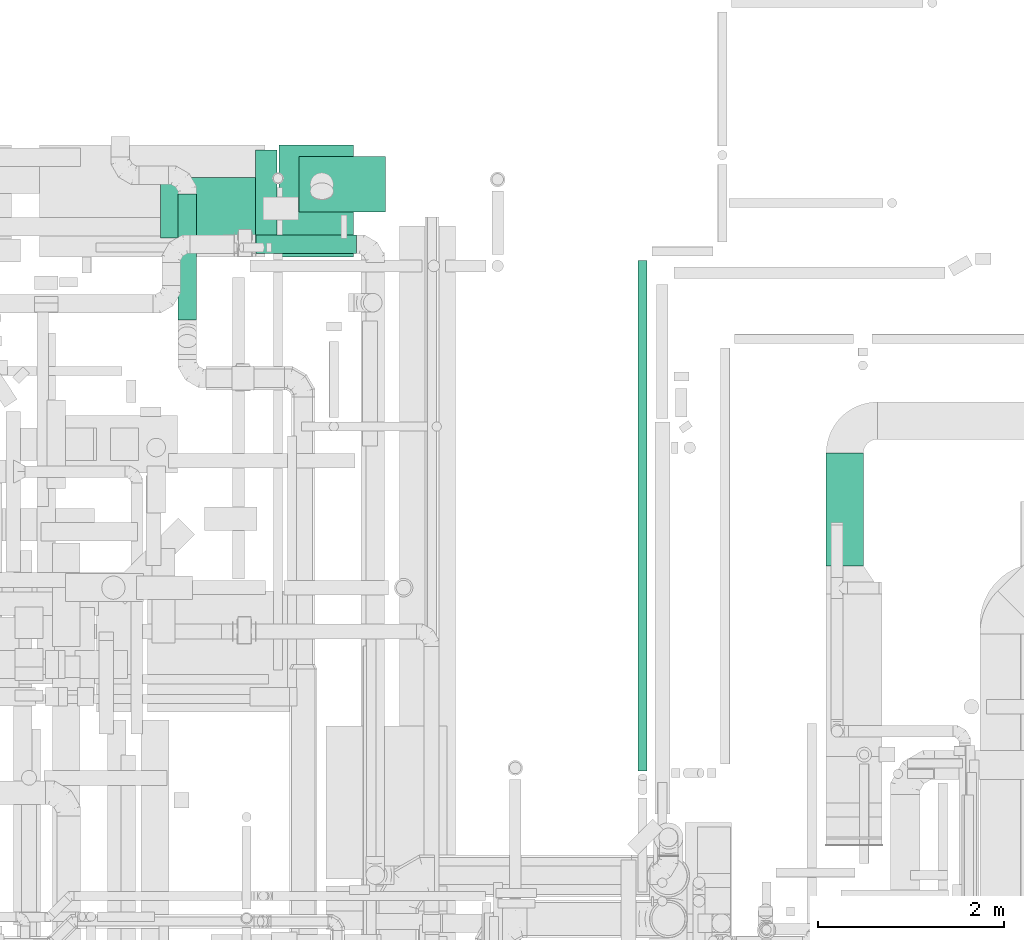
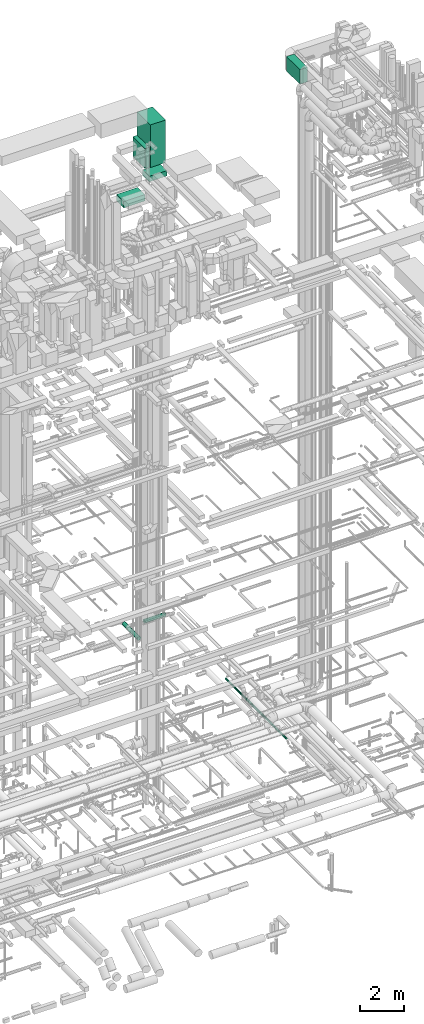
# One storey, part 79 of 337: 8 flow segments.
"""IFC2X3 building model written with IfcOpenShell, lengths in millimetres."""

from ifc_helpers import new_model, entity, si_unit, converted_unit, derived_unit, direction, frame, origin, origin_2d_with_axis, place, context, subcontext, project, spatial, rectangle, circle, extrude, type_object, element, save


model = new_model("IFC2X3")

# Units and contexts
model_context = context("Model", 3, precision=0.01, world=origin(), true_north=direction((6.12303176911189e-17, 1.0)))
body_context = subcontext(model_context, "Body", "Model", "MODEL_VIEW")
ifc_project = project(units=[si_unit("LENGTHUNIT", "METRE", prefix="MILLI"), si_unit("AREAUNIT", "SQUARE_METRE"), si_unit("VOLUMEUNIT", "CUBIC_METRE"), converted_unit("PLANEANGLEUNIT", "DEGREE", entity("IfcRatioMeasure", 0.0174532925199433), si_unit("PLANEANGLEUNIT", "RADIAN"), dimensions=[0, 0, 0, 0, 0, 0, 0]), si_unit("MASSUNIT", "GRAM", prefix="KILO"), derived_unit("MASSDENSITYUNIT", [(si_unit("MASSUNIT", "GRAM", prefix="KILO"), 1), (si_unit("LENGTHUNIT", "METRE"), -3)]), derived_unit("MOMENTOFINERTIAUNIT", [(si_unit("LENGTHUNIT", "METRE"), 4)]), si_unit("TIMEUNIT", "SECOND"), si_unit("FREQUENCYUNIT", "HERTZ"), si_unit("THERMODYNAMICTEMPERATUREUNIT", "DEGREE_CELSIUS"), derived_unit("THERMALTRANSMITTANCEUNIT", [(si_unit("MASSUNIT", "GRAM", prefix="KILO"), 1), (si_unit("THERMODYNAMICTEMPERATUREUNIT", "KELVIN"), -1), (si_unit("TIMEUNIT", "SECOND"), -3)]), derived_unit("VOLUMETRICFLOWRATEUNIT", [(si_unit("LENGTHUNIT", "METRE"), 3), (si_unit("TIMEUNIT", "SECOND"), -1)]), derived_unit("MASSFLOWRATEUNIT", [(si_unit("MASSUNIT", "GRAM", prefix="KILO"), 1), (si_unit("TIMEUNIT", "SECOND"), -1)]), derived_unit("ROTATIONALFREQUENCYUNIT", [(si_unit("TIMEUNIT", "SECOND"), -1)]), si_unit("ELECTRICCURRENTUNIT", "AMPERE"), si_unit("ELECTRICVOLTAGEUNIT", "VOLT"), si_unit("POWERUNIT", "WATT"), si_unit("FORCEUNIT", "NEWTON", prefix="KILO"), si_unit("ILLUMINANCEUNIT", "LUX"), si_unit("LUMINOUSFLUXUNIT", "LUMEN"), si_unit("LUMINOUSINTENSITYUNIT", "CANDELA"), derived_unit("USERDEFINED", [(si_unit("MASSUNIT", "GRAM", prefix="KILO"), -1), (si_unit("LENGTHUNIT", "METRE"), -2), (si_unit("TIMEUNIT", "SECOND"), 3), (si_unit("LUMINOUSFLUXUNIT", "LUMEN"), 1)]), derived_unit("LINEARVELOCITYUNIT", [(si_unit("LENGTHUNIT", "METRE"), 1), (si_unit("TIMEUNIT", "SECOND"), -1)]), si_unit("PRESSUREUNIT", "PASCAL"), derived_unit("USERDEFINED", [(si_unit("LENGTHUNIT", "METRE"), -2), (si_unit("MASSUNIT", "GRAM", prefix="KILO"), 1), (si_unit("TIMEUNIT", "SECOND"), -2)]), derived_unit("LINEARFORCEUNIT", [(si_unit("MASSUNIT", "GRAM", prefix="KILO"), 1), (si_unit("LENGTHUNIT", "METRE"), 1), (si_unit("TIMEUNIT", "SECOND"), -2), (si_unit("LENGTHUNIT", "METRE"), -1)]), derived_unit("PLANARFORCEUNIT", [(si_unit("MASSUNIT", "GRAM", prefix="KILO"), 1), (si_unit("LENGTHUNIT", "METRE"), 1), (si_unit("TIMEUNIT", "SECOND"), -2), (si_unit("LENGTHUNIT", "METRE"), -2)])], contexts=[model_context])

# Site, building, storey
site_placement = place(None, origin())
site = spatial("IfcSite", under=ifc_project, at=site_placement, CompositionType="ELEMENT")
building_placement = place(site_placement, origin())
building = spatial("IfcBuilding", under=site, at=building_placement, CompositionType="ELEMENT")
storey_placement = place(building_placement, origin())
storey = spatial("IfcBuildingStorey", under=building, at=storey_placement, CompositionType="ELEMENT", Elevation=0.0)

# Flow segments
duct_segment_type_1 = type_object("IfcDuctSegmentType", PredefinedType="NOTDEFINED")
flow_segment_1_placement = place(storey_placement, frame((63590.82, 19383.98, 27450.0)))
element("IfcFlowSegment", 1, at=flow_segment_1_placement, inside=storey, type_object=duct_segment_type_1, context=body_context, shape_type="SweptSolid", body=[
    extrude(rectangle(XDim=929.178951127788, YDim=599.999999999998, at=origin_2d_with_axis()), frame((464.59, 300.0, 0.0), z_axis=(0.0, 0.0, 1.0), x_axis=(-1.0, 0.0, 0.0)), (0.0, 0.0, 1.0), 300.000000000001),
])
flow_segment_2_placement = place(storey_placement, frame((63373.17, 18904.6, 28600.0)))
element("IfcFlowSegment", 2, at=flow_segment_2_placement, inside=storey, type_object=duct_segment_type_1, context=body_context, shape_type="SweptSolid", body=[
    extrude(rectangle(XDim=799.999999999991, YDim=1200.0, at=origin_2d_with_axis()), frame((400.0, 600.0, 0.0), z_axis=(0.0, 0.0, 1.0), x_axis=(-1.0, 0.0, 0.0)), (0.0, 0.0, 1.0), 2349.99997500001),
])
flow_segment_3_placement = place(storey_placement, frame((69255.37, 15583.61, 33150.0)))
element("IfcFlowSegment", 3, at=flow_segment_3_placement, inside=storey, type_object=duct_segment_type_1, context=body_context, shape_type="SweptSolid", body=[
    extrude(rectangle(XDim=1210.00000000001, YDim=400.000000000004, at=origin_2d_with_axis()), frame((200.0, 605.0, 0.0), z_axis=(0.0, 0.0, 1.0), x_axis=(0.0, -1.0, 0.0)), (0.0, 0.0, 1.0), 800.0),
])
flow_segment_4_placement = place(storey_placement, frame((62102.38, 19108.98, 26700.0)))
element("IfcFlowSegment", 4, at=flow_segment_4_placement, inside=storey, type_object=duct_segment_type_1, context=body_context, shape_type="SweptSolid", body=[
    extrude(rectangle(XDim=1100.0, YDim=650.0, at=origin_2d_with_axis()), frame((550.0, 325.0, 0.0)), (0.0, 0.0, 1.0), 349.999999999998),
])
duct_segment_type_2 = type_object("IfcDuctSegmentType", PredefinedType="NOTDEFINED")
flow_segment_5_placement = place(storey_placement, frame((67230.68, 13380.85, -951.6)))
element("IfcFlowSegment", 5, at=flow_segment_5_placement, inside=storey, type_object=duct_segment_type_2, context=body_context, shape_type="SweptSolid", body=[
    extrude(circle(Radius=50.0, at=origin_2d_with_axis()), frame((51.6, 0.0, 51.6), z_axis=(0.0, 1.0, 0.0), x_axis=(1.0, 0.0, 0.0)), (0.0, 0.0, 1.0), 5483.0840137627),
])
flow_segment_6_placement = place(storey_placement, frame((62288.55, 18222.95, 3298.4)))
element("IfcFlowSegment", 6, at=flow_segment_6_placement, inside=storey, type_object=duct_segment_type_2, context=body_context, shape_type="SweptSolid", body=[
    extrude(circle(Radius=100.0, at=origin_2d_with_axis()), frame((101.6, 0.0, 101.6), z_axis=(0.0, 1.0, 0.0), x_axis=(1.0, 0.0, 0.0)), (0.0, 0.0, 1.0), 1356.43727019989),
])
flow_segment_7_placement = place(storey_placement, frame((63127.5, 18939.21, 3498.4)))
element("IfcFlowSegment", 7, at=flow_segment_7_placement, inside=storey, type_object=duct_segment_type_2, context=body_context, shape_type="SweptSolid", body=[
    extrude(circle(Radius=100.0, at=origin_2d_with_axis()), frame((0.0, 101.6, 101.6), z_axis=(1.0, 0.0, 0.0), x_axis=(0.0, 1.0, 0.0)), (0.0, 0.0, 1.0), 1082.6436989123),
])
duct_segment_type_3 = type_object("IfcDuctSegmentType", PredefinedType="NOTDEFINED")
flow_segment_8_placement = place(storey_placement, frame((63122.46, 18954.6, 28600.0)))
element("IfcFlowSegment", 8, at=flow_segment_8_placement, inside=storey, type_object=duct_segment_type_3, context=body_context, shape_type="SweptSolid", body=[
    extrude(rectangle(XDim=230.704544349522, YDim=1100.0, at=origin_2d_with_axis()), frame((115.35, 550.0, 0.0), z_axis=(0.0, 0.0, 1.0), x_axis=(-1.0, 0.0, 0.0)), (0.0, 0.0, 1.0), 1100.0),
])

save(model, "model.ifc")
